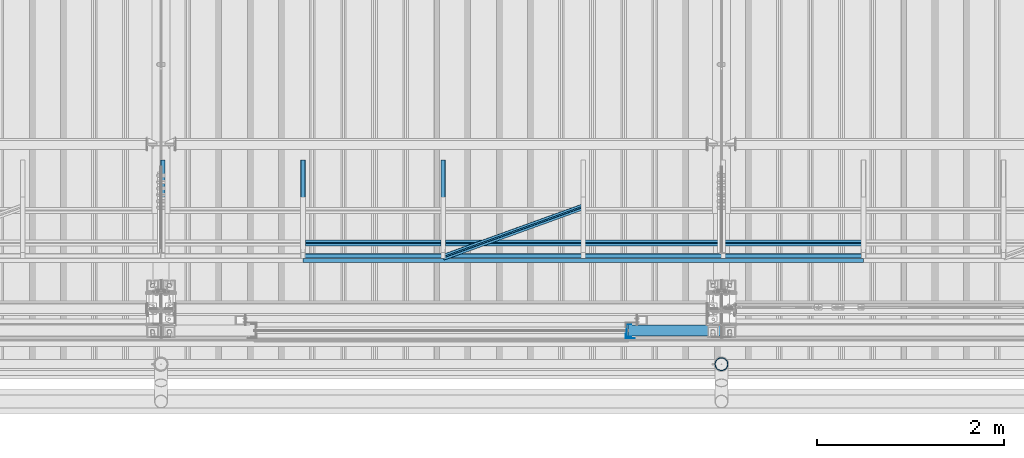
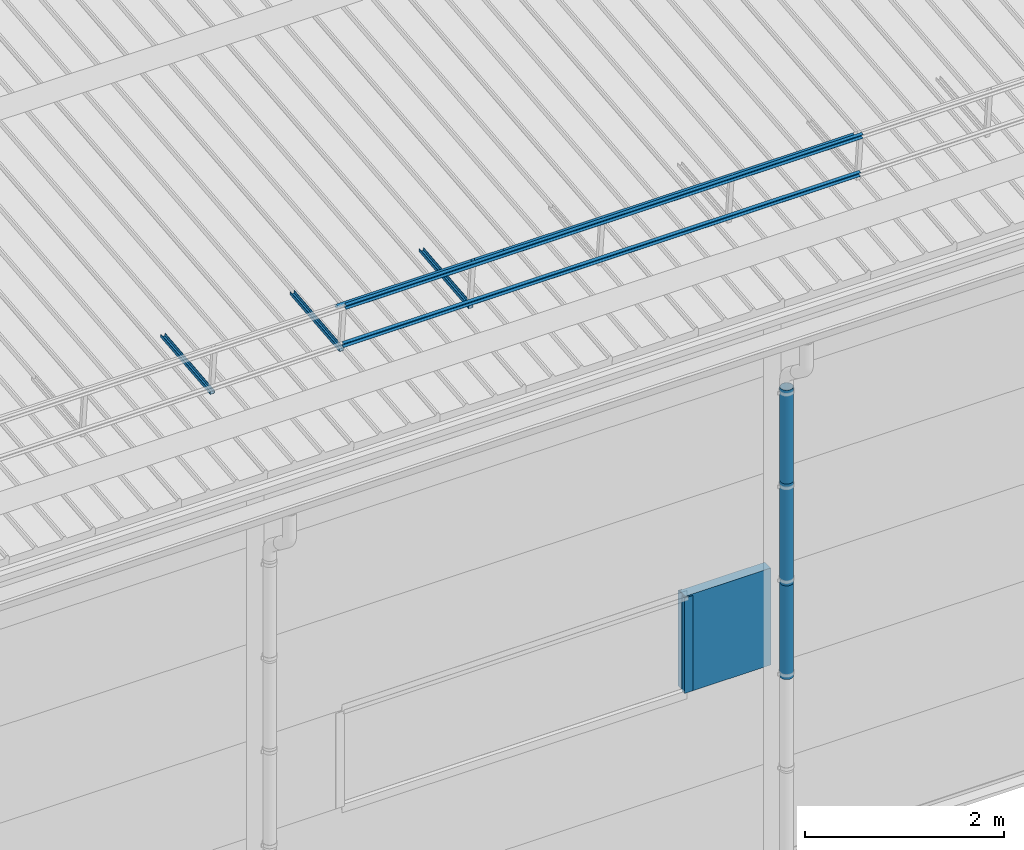
# One storey, part 42 of 709: 13 beams, 13 elements without a shape of their own.
"""IFC4 building model written with IfcOpenShell, lengths in millimetres."""

from ifc_helpers import new_model, si_unit, direction, frame, origin_with_axes, place, context, subcontext, project, spatial, line, indexed_curve, outline, extrude, material, element, aggregate, save


model = new_model("IFC4")

# Units and contexts
model_context = context("Model", 3, precision=0.2, world=origin_with_axes(), true_north=direction((0.0, 1.0)))
body_context = subcontext(model_context, "Body", "Model", "MODEL_VIEW")
ifc_project = project(units=[si_unit("LENGTHUNIT", "METRE", prefix="MILLI"), si_unit("AREAUNIT", "SQUARE_METRE"), si_unit("VOLUMEUNIT", "CUBIC_METRE"), si_unit("MASSUNIT", "GRAM", prefix="KILO"), si_unit("TIMEUNIT", "SECOND"), si_unit("PLANEANGLEUNIT", "RADIAN"), si_unit("SOLIDANGLEUNIT", "STERADIAN"), si_unit("THERMODYNAMICTEMPERATUREUNIT", "DEGREE_CELSIUS"), si_unit("LUMINOUSINTENSITYUNIT", "LUMEN")], contexts=[model_context])

# Site, building, storey
site_placement = place(None, origin_with_axes())
site = spatial("IfcSite", under=ifc_project, at=site_placement, CompositionType="ELEMENT")
building_placement = place(site_placement, origin_with_axes())
building = spatial("IfcBuilding", under=site, at=building_placement, Name="Undefined", CompositionType="ELEMENT")
storey_placement = place(building_placement, origin_with_axes())
storey = spatial("IfcBuildingStorey", under=building, at=storey_placement, Name="Undefined", CompositionType="ELEMENT", Elevation=0.0)

# Assembly, beam
assembly_1_placement = place(storey_placement, frame((16020.0, 768.92298, 7577.16191), z_axis=(0.0, -0.099503719, 0.9950371902), x_axis=(0.0, 0.9950371902, 0.099503719)))
assembly_1 = element("IfcElementAssembly", 1, at=assembly_1_placement, inside=storey)
ifc_material_1 = material(Name="Steel_Undefined", Category="STEEL")
beam_1_placement = place(assembly_1_placement, origin_with_axes())
beam_1 = element("IfcBeam", 2, at=beam_1_placement, material=ifc_material_1, ObjectType="601", context=body_context, shape_type="SolidModel", body=[
    extrude(outline(indexed_curve([(-20.0, -25.0), (20.0, -25.0), (20.0, -22.5), (-17.5, -22.5), (-17.5, 22.5), (20.0, 22.5), (20.0, 25.0), (-20.0, 25.0)], segments=[line(1, 2, 3, 4, 5, 6, 7, 8, 1)])), frame((0.0, 0.0, 0.0), z_axis=(-1.0, 0.0, 0.0), x_axis=(0.0, 0.0, 1.0)), (0.0, 0.0, -1.0), 1000.0),
])
aggregate(assembly_1, [beam_1])

assembly_2_placement = place(storey_placement, frame((17520.0, 768.92298, 7577.16191), z_axis=(0.0, -0.099503719, 0.9950371902), x_axis=(0.0, 0.9950371902, 0.099503719)))
assembly_2 = element("IfcElementAssembly", 3, at=assembly_2_placement, inside=storey)
beam_2_placement = place(assembly_2_placement, origin_with_axes())
beam_2 = element("IfcBeam", 4, at=beam_2_placement, material=ifc_material_1, ObjectType="601", context=body_context, shape_type="SolidModel", body=[
    extrude(outline(indexed_curve([(-20.0, -25.0), (20.0, -25.0), (20.0, -22.5), (-17.5, -22.5), (-17.5, 22.5), (20.0, 22.5), (20.0, 25.0), (-20.0, 25.0)], segments=[line(1, 2, 3, 4, 5, 6, 7, 8, 1)])), frame((0.0, 0.0, 0.0), z_axis=(-1.0, 0.0, 0.0), x_axis=(0.0, 0.0, 1.0)), (0.0, 0.0, -1.0), 1000.0),
])
aggregate(assembly_2, [beam_2])

assembly_3_placement = place(storey_placement, frame((19020.0, 768.92298, 7577.16191), z_axis=(0.0, -0.099503719, 0.9950371902), x_axis=(0.0, 0.9950371902, 0.099503719)))
assembly_3 = element("IfcElementAssembly", 5, at=assembly_3_placement, inside=storey)
beam_3_placement = place(assembly_3_placement, origin_with_axes())
beam_3 = element("IfcBeam", 6, at=beam_3_placement, material=ifc_material_1, ObjectType="601", context=body_context, shape_type="SolidModel", body=[
    extrude(outline(indexed_curve([(-20.0, -25.0), (20.0, -25.0), (20.0, -22.5), (-17.5, -22.5), (-17.5, 22.5), (20.0, 22.5), (20.0, 25.0), (-20.0, 25.0)], segments=[line(1, 2, 3, 4, 5, 6, 7, 8, 1)])), frame((0.0, 0.0, 0.0), z_axis=(-1.0, 0.0, 0.0), x_axis=(0.0, 0.0, 1.0)), (0.0, 0.0, -1.0), 1000.0),
])
aggregate(assembly_3, [beam_3])

assembly_4_placement = place(storey_placement, frame((17520.0, 691.31008, 8152.29341), z_axis=(0.0, -0.9950371902, -0.099503719), x_axis=(1.0, 0.0, 0.0)))
assembly_4 = element("IfcElementAssembly", 7, at=assembly_4_placement, inside=storey)
beam_4_placement = place(assembly_4_placement, origin_with_axes())
beam_4 = element("IfcBeam", 8, at=beam_4_placement, material=ifc_material_1, ObjectType="606", context=body_context, shape_type="SolidModel", body=[
    extrude(outline(indexed_curve([(-20.0, -25.0), (20.0, -25.0), (20.0, -22.5), (-17.5, -22.5), (-17.5, 22.5), (20.0, 22.5), (20.0, 25.0), (-20.0, 25.0)], segments=[line(1, 2, 3, 4, 5, 6, 7, 8, 1)])), frame((0.0, 0.0, 0.0), z_axis=(-1.0, 0.0, 0.0), x_axis=(0.0, 0.0, 1.0)), (0.0, 0.0, -1.0), 6000.0),
])
aggregate(assembly_4, [beam_4])

assembly_5_placement = place(storey_placement, frame((17520.0, 741.06194, 7654.77481), z_axis=(0.0, -0.9950371902, -0.099503719), x_axis=(1.0, 0.0, 0.0)))
assembly_5 = element("IfcElementAssembly", 9, at=assembly_5_placement, inside=storey)
beam_5_placement = place(assembly_5_placement, origin_with_axes())
beam_5 = element("IfcBeam", 10, at=beam_5_placement, material=ifc_material_1, ObjectType="606", context=body_context, shape_type="SolidModel", body=[
    extrude(outline(indexed_curve([(-20.0, -25.0), (20.0, -25.0), (20.0, -22.5), (-17.5, -22.5), (-17.5, 22.5), (20.0, 22.5), (20.0, 25.0), (-20.0, 25.0)], segments=[line(1, 2, 3, 4, 5, 6, 7, 8, 1)])), frame((0.0, 0.0, 0.0), z_axis=(-1.0, 0.0, 0.0), x_axis=(0.0, 0.0, 1.0)), (0.0, 0.0, -1.0), 6000.0),
])
aggregate(assembly_5, [beam_5])

assembly_6_placement = place(storey_placement, frame((17520.0, 878.66704, 8043.11507), z_axis=(0.0, 0.6332377902, 0.7739572992), x_axis=(1.0, 0.0, 0.0)))
assembly_6 = element("IfcElementAssembly", 11, at=assembly_6_placement, inside=storey)
beam_6_placement = place(assembly_6_placement, origin_with_axes())
beam_6 = element("IfcBeam", 12, at=beam_6_placement, material=ifc_material_1, ObjectType="606", context=body_context, shape_type="SolidModel", body=[
    extrude(outline(indexed_curve([(-20.0, -25.0), (20.0, -25.0), (20.0, -22.5), (-17.5, -22.5), (-17.5, 22.5), (20.0, 22.5), (20.0, 25.0), (-20.0, 25.0)], segments=[line(1, 2, 3, 4, 5, 6, 7, 8, 1)])), frame((0.0, 0.0, 0.0), z_axis=(-1.0, 0.0, 0.0), x_axis=(0.0, 0.0, 1.0)), (0.0, 0.0, -1.0), 6000.0),
])
aggregate(assembly_6, [beam_6])

assembly_7_placement = place(storey_placement, frame((19020.0, 723.87558, 8169.76263), z_axis=(0.0, 0.6332377902, 0.7739572992), x_axis=(0.9061831398, 0.3272952929, -0.2677870579)))
assembly_7 = element("IfcElementAssembly", 13, at=assembly_7_placement, inside=storey)
beam_7_placement = place(assembly_7_placement, origin_with_axes())
beam_7 = element("IfcBeam", 14, at=beam_7_placement, material=ifc_material_1, ObjectType="605", context=body_context, shape_type="SolidModel", body=[
    extrude(outline(indexed_curve([(-20.0, -25.0), (20.0, -25.0), (20.0, -22.5), (-17.5, -22.5), (-17.5, 22.5), (20.0, 22.5), (20.0, 25.0), (-20.0, 25.0)], segments=[line(1, 2, 3, 4, 5, 6, 7, 8, 1)])), frame((0.0, 0.0, 0.0), z_axis=(-1.0, 0.0, 0.0), x_axis=(0.0, 0.0, 1.0)), (0.0, 0.0, -1.0), 1655.29454),
])
aggregate(assembly_7, [beam_7])

assembly_8_placement = place(storey_placement, frame((21000.0, -60.0, 3275.0), z_axis=(0.0, 0.0, -1.0), x_axis=(1.0, 0.0, 0.0)))
assembly_8 = element("IfcElementAssembly", 15, at=assembly_8_placement, inside=storey)
ifc_material_2 = material(Name="Insulation", Category="Insulation")
beam_8_placement = place(assembly_8_placement, origin_with_axes())
beam_8 = element("IfcBeam", 16, at=beam_8_placement, material=ifc_material_2, ObjectType="P-110", context=body_context, shape_type="SolidModel", body=[
    extrude(outline(indexed_curve([(-595.0, -60.0), (595.0, -60.0), (595.0, 60.0), (-595.0, 60.0)], segments=[line(1, 2, 3, 4, 1)])), frame((0.0, 0.0, 0.0), z_axis=(-1.0, 0.0, 0.0), x_axis=(0.0, 0.0, 1.0)), (0.0, 0.0, -1.0), 990.0),
])
aggregate(assembly_8, [beam_8])

assembly_9_placement = place(storey_placement, frame((21010.0, -60.0, 3870.0), z_axis=(0.0, 1.0, 0.0), x_axis=(0.0, 0.0, -1.0)))
assembly_9 = element("IfcElementAssembly", 17, at=assembly_9_placement, inside=storey)
beam_9_placement = place(assembly_9_placement, origin_with_axes())
beam_9 = element("IfcBeam", 18, at=beam_9_placement, material=ifc_material_1, context=body_context, shape_type="SolidModel", body=[
    extrude(outline(indexed_curve([(-70.0, -25.0), (-68.0, -25.0), (-68.0, 23.0), (68.0, 23.0), (68.0, -25.0), (70.0, -25.0), (70.0, 25.0), (-70.0, 25.0)], segments=[line(1, 2, 3, 4, 5, 6, 7, 8, 1)])), frame((0.0, 0.0, 0.0), z_axis=(-1.0, 0.0, 0.0), x_axis=(0.0, 0.0, 1.0)), (0.0, 0.0, -1.0), 1170.0),
])
aggregate(assembly_9, [beam_9])

assembly_10_placement = place(storey_placement, frame((20975.0, -119.0, 3870.0), z_axis=(0.0, -1.0, 0.0), x_axis=(0.0, 0.0, -1.0)))
assembly_10 = element("IfcElementAssembly", 19, at=assembly_10_placement, inside=storey)
beam_10_placement = place(assembly_10_placement, origin_with_axes())
beam_10 = element("IfcBeam", 20, at=beam_10_placement, material=ifc_material_1, context=body_context, shape_type="SolidModel", body=[
    extrude(outline(indexed_curve([(-25.0, -1.0), (25.0, -1.0), (25.0, 99.0), (23.0, 99.0), (23.0, 1.0), (-25.0, 1.0)], segments=[line(1, 2, 3, 4, 5, 6, 1)])), frame((0.0, 0.0, 0.0), z_axis=(-1.0, 0.0, 0.0), x_axis=(0.0, 0.0, 1.0)), (0.0, 0.0, -1.0), 1170.0),
])
aggregate(assembly_10, [beam_10])

assembly_11_placement = place(storey_placement, frame((22000.0, -420.0, 6276.92297), z_axis=(0.0, 1.0, 0.0), x_axis=(0.0, 0.0, -1.0)))
assembly_11 = element("IfcElementAssembly", 21, at=assembly_11_placement, inside=storey)
beam_11_placement = place(assembly_11_placement, origin_with_axes())
beam_11 = element("IfcBeam", 22, at=beam_11_placement, material=ifc_material_1, ObjectType="614", context=body_context, shape_type="SolidModel", body=[
    extrude(outline(indexed_curve([(70.0, 0.0), (69.61653, 7.31699), (68.47033, 14.55382), (66.57396, 21.63119), (63.94818, 28.47157), (60.62178, 35.0), (56.63119, 41.14497), (52.02014, 46.83914), (46.83914, 52.02014), (41.14497, 56.63119), (35.0, 60.62178), (28.47157, 63.94818), (21.63119, 66.57396), (14.55382, 68.47033), (7.31699, 69.61653), (0.0, 70.0), (-7.31699, 69.61653), (-14.55382, 68.47033), (-21.63119, 66.57396), (-28.47157, 63.94818), (-35.0, 60.62178), (-41.14497, 56.63119), (-46.83914, 52.02014), (-52.02014, 46.83914), (-56.63119, 41.14497), (-60.62178, 35.0), (-63.94818, 28.47157), (-66.57396, 21.63119), (-68.47033, 14.55382), (-69.61653, 7.31699), (-70.0, 0.0), (-69.61653, -7.31699), (-68.47033, -14.55382), (-66.57396, -21.63119), (-63.94818, -28.47157), (-60.62178, -35.0), (-56.63119, -41.14497), (-52.02014, -46.83914), (-46.83914, -52.02014), (-41.14497, -56.63119), (-35.0, -60.62178), (-28.47157, -63.94818), (-21.63119, -66.57396), (-14.55382, -68.47033), (-7.31699, -69.61653), (0.0, -70.0), (7.31699, -69.61653), (14.55382, -68.47033), (21.63119, -66.57396), (28.47157, -63.94818), (35.0, -60.62178), (41.14497, -56.63119), (46.83914, -52.02014), (52.02014, -46.83914), (56.63119, -41.14497), (60.62178, -35.0), (63.94818, -28.47157), (66.57396, -21.63119), (68.47033, -14.55382), (69.61653, -7.31699)], segments=[line(1, 2, 3, 4, 5, 6, 7, 8, 9, 10, 11, 12, 13, 14, 15, 16, 17, 18, 19, 20, 21, 22, 23, 24, 25, 26, 27, 28, 29, 30, 31, 32, 33, 34, 35, 36, 37, 38, 39, 40, 41, 42, 43, 44, 45, 46, 47, 48, 49, 50, 51, 52, 53, 54, 55, 56, 57, 58, 59, 60, 1)]), holes=[indexed_curve([(65.0, 0.0), (64.64392, -6.79435), (63.57959, -13.51426), (61.81867, -20.0861), (59.38045, -26.43788), (56.29165, -32.5), (52.5861, -38.20604), (48.30441, -43.49349), (43.49349, -48.30441), (38.20604, -52.5861), (32.5, -56.29165), (26.43788, -59.38045), (20.0861, -61.81867), (13.51426, -63.57959), (6.79435, -64.64392), (0.0, -65.0), (-6.79435, -64.64392), (-13.51426, -63.57959), (-20.0861, -61.81867), (-26.43788, -59.38045), (-32.5, -56.29165), (-38.20604, -52.5861), (-43.49349, -48.30441), (-48.30441, -43.49349), (-52.5861, -38.20604), (-56.29165, -32.5), (-59.38045, -26.43788), (-61.81867, -20.0861), (-63.57959, -13.51426), (-64.64392, -6.79435), (-65.0, 0.0), (-64.64392, 6.79435), (-63.57959, 13.51426), (-61.81867, 20.0861), (-59.38045, 26.43788), (-56.29165, 32.5), (-52.5861, 38.20604), (-48.30441, 43.49349), (-43.49349, 48.30441), (-38.20604, 52.5861), (-32.5, 56.29165), (-26.43788, 59.38045), (-20.0861, 61.81867), (-13.51426, 63.57959), (-6.79435, 64.64392), (0.0, 65.0), (6.79435, 64.64392), (13.51426, 63.57959), (20.0861, 61.81867), (26.43788, 59.38045), (32.5, 56.29165), (38.20604, 52.5861), (43.49349, 48.30441), (48.30441, 43.49349), (52.5861, 38.20604), (56.29165, 32.5), (59.38045, 26.43788), (61.81867, 20.0861), (63.57959, 13.51426), (64.64392, 6.79435)], segments=[line(1, 2, 3, 4, 5, 6, 7, 8, 9, 10, 11, 12, 13, 14, 15, 16, 17, 18, 19, 20, 21, 22, 23, 24, 25, 26, 27, 28, 29, 30, 31, 32, 33, 34, 35, 36, 37, 38, 39, 40, 41, 42, 43, 44, 45, 46, 47, 48, 49, 50, 51, 52, 53, 54, 55, 56, 57, 58, 59, 60, 1)])]), frame((0.0, 0.0, 0.0), z_axis=(-1.0, 0.0, 0.0), x_axis=(0.0, 0.0, 1.0)), (0.0, 0.0, -1.0), 1250.0),
])
aggregate(assembly_11, [beam_11])

assembly_12_placement = place(storey_placement, frame((22000.0, -420.0, 5126.92297), z_axis=(0.0, 1.0, 0.0), x_axis=(0.0, 0.0, -1.0)))
assembly_12 = element("IfcElementAssembly", 23, at=assembly_12_placement, inside=storey)
beam_12_placement = place(assembly_12_placement, origin_with_axes())
beam_12 = element("IfcBeam", 24, at=beam_12_placement, material=ifc_material_1, ObjectType="614", context=body_context, shape_type="SolidModel", body=[
    extrude(outline(indexed_curve([(70.0, 0.0), (69.61653, 7.31699), (68.47033, 14.55382), (66.57396, 21.63119), (63.94818, 28.47157), (60.62178, 35.0), (56.63119, 41.14497), (52.02014, 46.83914), (46.83914, 52.02014), (41.14497, 56.63119), (35.0, 60.62178), (28.47157, 63.94818), (21.63119, 66.57396), (14.55382, 68.47033), (7.31699, 69.61653), (0.0, 70.0), (-7.31699, 69.61653), (-14.55382, 68.47033), (-21.63119, 66.57396), (-28.47157, 63.94818), (-35.0, 60.62178), (-41.14497, 56.63119), (-46.83914, 52.02014), (-52.02014, 46.83914), (-56.63119, 41.14497), (-60.62178, 35.0), (-63.94818, 28.47157), (-66.57396, 21.63119), (-68.47033, 14.55382), (-69.61653, 7.31699), (-70.0, 0.0), (-69.61653, -7.31699), (-68.47033, -14.55382), (-66.57396, -21.63119), (-63.94818, -28.47157), (-60.62178, -35.0), (-56.63119, -41.14497), (-52.02014, -46.83914), (-46.83914, -52.02014), (-41.14497, -56.63119), (-35.0, -60.62178), (-28.47157, -63.94818), (-21.63119, -66.57396), (-14.55382, -68.47033), (-7.31699, -69.61653), (0.0, -70.0), (7.31699, -69.61653), (14.55382, -68.47033), (21.63119, -66.57396), (28.47157, -63.94818), (35.0, -60.62178), (41.14497, -56.63119), (46.83914, -52.02014), (52.02014, -46.83914), (56.63119, -41.14497), (60.62178, -35.0), (63.94818, -28.47157), (66.57396, -21.63119), (68.47033, -14.55382), (69.61653, -7.31699)], segments=[line(1, 2, 3, 4, 5, 6, 7, 8, 9, 10, 11, 12, 13, 14, 15, 16, 17, 18, 19, 20, 21, 22, 23, 24, 25, 26, 27, 28, 29, 30, 31, 32, 33, 34, 35, 36, 37, 38, 39, 40, 41, 42, 43, 44, 45, 46, 47, 48, 49, 50, 51, 52, 53, 54, 55, 56, 57, 58, 59, 60, 1)]), holes=[indexed_curve([(65.0, 0.0), (64.64392, -6.79435), (63.57959, -13.51426), (61.81867, -20.0861), (59.38045, -26.43788), (56.29165, -32.5), (52.5861, -38.20604), (48.30441, -43.49349), (43.49349, -48.30441), (38.20604, -52.5861), (32.5, -56.29165), (26.43788, -59.38045), (20.0861, -61.81867), (13.51426, -63.57959), (6.79435, -64.64392), (0.0, -65.0), (-6.79435, -64.64392), (-13.51426, -63.57959), (-20.0861, -61.81867), (-26.43788, -59.38045), (-32.5, -56.29165), (-38.20604, -52.5861), (-43.49349, -48.30441), (-48.30441, -43.49349), (-52.5861, -38.20604), (-56.29165, -32.5), (-59.38045, -26.43788), (-61.81867, -20.0861), (-63.57959, -13.51426), (-64.64392, -6.79435), (-65.0, 0.0), (-64.64392, 6.79435), (-63.57959, 13.51426), (-61.81867, 20.0861), (-59.38045, 26.43788), (-56.29165, 32.5), (-52.5861, 38.20604), (-48.30441, 43.49349), (-43.49349, 48.30441), (-38.20604, 52.5861), (-32.5, 56.29165), (-26.43788, 59.38045), (-20.0861, 61.81867), (-13.51426, 63.57959), (-6.79435, 64.64392), (0.0, 65.0), (6.79435, 64.64392), (13.51426, 63.57959), (20.0861, 61.81867), (26.43788, 59.38045), (32.5, 56.29165), (38.20604, 52.5861), (43.49349, 48.30441), (48.30441, 43.49349), (52.5861, 38.20604), (56.29165, 32.5), (59.38045, 26.43788), (61.81867, 20.0861), (63.57959, 13.51426), (64.64392, 6.79435)], segments=[line(1, 2, 3, 4, 5, 6, 7, 8, 9, 10, 11, 12, 13, 14, 15, 16, 17, 18, 19, 20, 21, 22, 23, 24, 25, 26, 27, 28, 29, 30, 31, 32, 33, 34, 35, 36, 37, 38, 39, 40, 41, 42, 43, 44, 45, 46, 47, 48, 49, 50, 51, 52, 53, 54, 55, 56, 57, 58, 59, 60, 1)])]), frame((0.0, 0.0, 0.0), z_axis=(-1.0, 0.0, 0.0), x_axis=(0.0, 0.0, 1.0)), (0.0, 0.0, -1.0), 1250.0),
])
aggregate(assembly_12, [beam_12])

assembly_13_placement = place(storey_placement, frame((22000.0, -420.0, 3976.92297), z_axis=(0.0, 1.0, 0.0), x_axis=(0.0, 0.0, -1.0)))
assembly_13 = element("IfcElementAssembly", 25, at=assembly_13_placement, inside=storey)
beam_13_placement = place(assembly_13_placement, origin_with_axes())
beam_13 = element("IfcBeam", 26, at=beam_13_placement, material=ifc_material_1, ObjectType="614", context=body_context, shape_type="SolidModel", body=[
    extrude(outline(indexed_curve([(70.0, 0.0), (69.61653, 7.31699), (68.47033, 14.55382), (66.57396, 21.63119), (63.94818, 28.47157), (60.62178, 35.0), (56.63119, 41.14497), (52.02014, 46.83914), (46.83914, 52.02014), (41.14497, 56.63119), (35.0, 60.62178), (28.47157, 63.94818), (21.63119, 66.57396), (14.55382, 68.47033), (7.31699, 69.61653), (0.0, 70.0), (-7.31699, 69.61653), (-14.55382, 68.47033), (-21.63119, 66.57396), (-28.47157, 63.94818), (-35.0, 60.62178), (-41.14497, 56.63119), (-46.83914, 52.02014), (-52.02014, 46.83914), (-56.63119, 41.14497), (-60.62178, 35.0), (-63.94818, 28.47157), (-66.57396, 21.63119), (-68.47033, 14.55382), (-69.61653, 7.31699), (-70.0, 0.0), (-69.61653, -7.31699), (-68.47033, -14.55382), (-66.57396, -21.63119), (-63.94818, -28.47157), (-60.62178, -35.0), (-56.63119, -41.14497), (-52.02014, -46.83914), (-46.83914, -52.02014), (-41.14497, -56.63119), (-35.0, -60.62178), (-28.47157, -63.94818), (-21.63119, -66.57396), (-14.55382, -68.47033), (-7.31699, -69.61653), (0.0, -70.0), (7.31699, -69.61653), (14.55382, -68.47033), (21.63119, -66.57396), (28.47157, -63.94818), (35.0, -60.62178), (41.14497, -56.63119), (46.83914, -52.02014), (52.02014, -46.83914), (56.63119, -41.14497), (60.62178, -35.0), (63.94818, -28.47157), (66.57396, -21.63119), (68.47033, -14.55382), (69.61653, -7.31699)], segments=[line(1, 2, 3, 4, 5, 6, 7, 8, 9, 10, 11, 12, 13, 14, 15, 16, 17, 18, 19, 20, 21, 22, 23, 24, 25, 26, 27, 28, 29, 30, 31, 32, 33, 34, 35, 36, 37, 38, 39, 40, 41, 42, 43, 44, 45, 46, 47, 48, 49, 50, 51, 52, 53, 54, 55, 56, 57, 58, 59, 60, 1)]), holes=[indexed_curve([(65.0, 0.0), (64.64392, -6.79435), (63.57959, -13.51426), (61.81867, -20.0861), (59.38045, -26.43788), (56.29165, -32.5), (52.5861, -38.20604), (48.30441, -43.49349), (43.49349, -48.30441), (38.20604, -52.5861), (32.5, -56.29165), (26.43788, -59.38045), (20.0861, -61.81867), (13.51426, -63.57959), (6.79435, -64.64392), (0.0, -65.0), (-6.79435, -64.64392), (-13.51426, -63.57959), (-20.0861, -61.81867), (-26.43788, -59.38045), (-32.5, -56.29165), (-38.20604, -52.5861), (-43.49349, -48.30441), (-48.30441, -43.49349), (-52.5861, -38.20604), (-56.29165, -32.5), (-59.38045, -26.43788), (-61.81867, -20.0861), (-63.57959, -13.51426), (-64.64392, -6.79435), (-65.0, 0.0), (-64.64392, 6.79435), (-63.57959, 13.51426), (-61.81867, 20.0861), (-59.38045, 26.43788), (-56.29165, 32.5), (-52.5861, 38.20604), (-48.30441, 43.49349), (-43.49349, 48.30441), (-38.20604, 52.5861), (-32.5, 56.29165), (-26.43788, 59.38045), (-20.0861, 61.81867), (-13.51426, 63.57959), (-6.79435, 64.64392), (0.0, 65.0), (6.79435, 64.64392), (13.51426, 63.57959), (20.0861, 61.81867), (26.43788, 59.38045), (32.5, 56.29165), (38.20604, 52.5861), (43.49349, 48.30441), (48.30441, 43.49349), (52.5861, 38.20604), (56.29165, 32.5), (59.38045, 26.43788), (61.81867, 20.0861), (63.57959, 13.51426), (64.64392, 6.79435)], segments=[line(1, 2, 3, 4, 5, 6, 7, 8, 9, 10, 11, 12, 13, 14, 15, 16, 17, 18, 19, 20, 21, 22, 23, 24, 25, 26, 27, 28, 29, 30, 31, 32, 33, 34, 35, 36, 37, 38, 39, 40, 41, 42, 43, 44, 45, 46, 47, 48, 49, 50, 51, 52, 53, 54, 55, 56, 57, 58, 59, 60, 1)])]), frame((0.0, 0.0, 0.0), z_axis=(-1.0, 0.0, 0.0), x_axis=(0.0, 0.0, 1.0)), (0.0, 0.0, -1.0), 1250.0),
])
aggregate(assembly_13, [beam_13])

save(model, "model.ifc")
